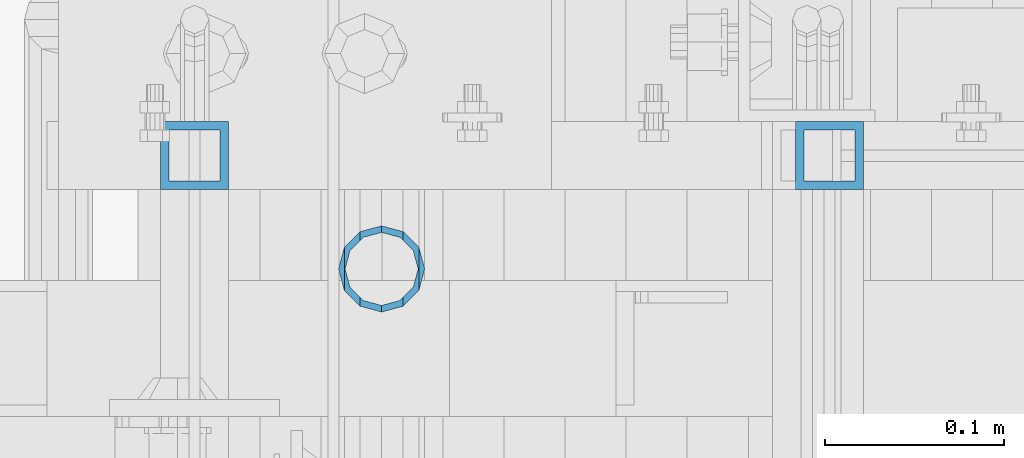
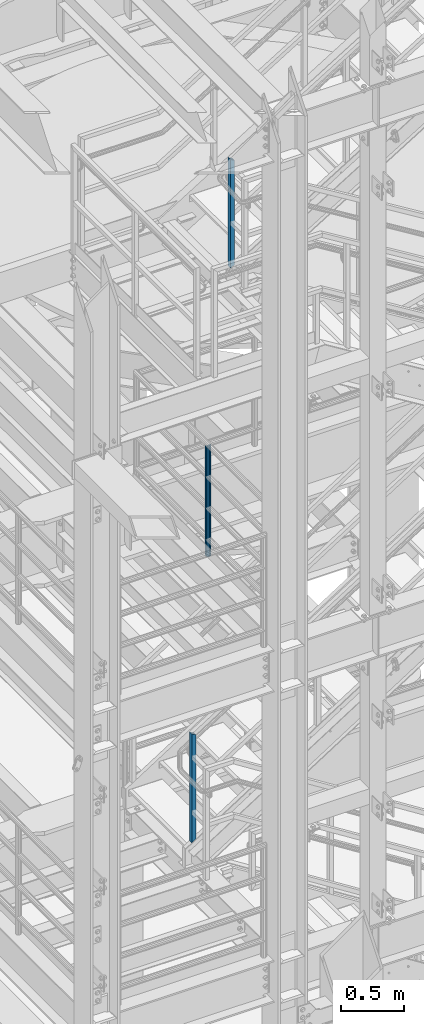
# One storey, part 602 of 1876: 3 columns, 3 elements without a shape of their own.
"""IFC2X3 building model written with IfcOpenShell, lengths in millimetres."""

from ifc_helpers import new_model, si_unit, frame, origin_with_axes, place, context, subcontext, project, spatial, faceted_brep, material, type_object, element, aggregate, save


model = new_model("IFC2X3")

# Units and contexts
model_context = context("Model", 3, precision=1e-05, world=origin_with_axes())
body_context = subcontext(model_context, "Body", "Model", "MODEL_VIEW")
ifc_project = project(units=[si_unit("LENGTHUNIT", "METRE", prefix="MILLI"), si_unit("AREAUNIT", "SQUARE_METRE"), si_unit("VOLUMEUNIT", "CUBIC_METRE"), si_unit("MASSUNIT", "GRAM", prefix="KILO"), si_unit("TIMEUNIT", "SECOND"), si_unit("PLANEANGLEUNIT", "RADIAN"), si_unit("SOLIDANGLEUNIT", "STERADIAN"), si_unit("THERMODYNAMICTEMPERATUREUNIT", "DEGREE_CELSIUS"), si_unit("LUMINOUSINTENSITYUNIT", "LUMEN")], contexts=[model_context])

# Site, building, storey
site_placement = place(None, origin_with_axes())
site = spatial("IfcSite", under=ifc_project, at=site_placement, CompositionType="ELEMENT")
building_placement = place(site_placement, origin_with_axes())
building = spatial("IfcBuilding", under=site, at=building_placement, Name="Undefined", CompositionType="ELEMENT")
storey_placement = place(building_placement, origin_with_axes())
storey = spatial("IfcBuildingStorey", under=building, at=storey_placement, Name="Undefined", CompositionType="ELEMENT", Elevation=0.0)

# Assembly, column
assembly_1_placement = place(storey_placement, origin_with_axes())
assembly_1 = element("IfcElementAssembly", 1, at=assembly_1_placement, inside=storey, Name="RAIL", AssemblyPlace="NOTDEFINED", PredefinedType="RIGID_FRAME")
ifc_material_1 = material()
column_type_1 = type_object("IfcColumnType", Name="HSS1-1/2X1-1/2X3/16", PredefinedType="NOTDEFINED")
column_1_placement = place(assembly_1_placement, frame((1676.39999919088, -5734.05000114554, 5380.55913395095), z_axis=(-1.0, 0.0, 0.0), x_axis=(0.0, 0.0, 1.0)))
column_1 = element("IfcColumn", 2, at=column_1_placement, type_object=column_type_1, material=ifc_material_1, Name="POST", ObjectType="HSS1-1/2X1-1/2X3/16", context=body_context, shape_type="Brep", body=[
    faceted_brep([(9.09204508312268, 14.2874994260001, -14.2874994260001), (9.09204508312268, -14.2874994260001, -14.2874994260001), (1028.85007387741, -14.2874994260001, -14.2874994260001), (1028.85007387741, 14.2874994260001, -14.2874994260001), (-9.09204508310631, -14.2874994260001, 14.2874994260001), (1044.53620210125, -14.2874994260001, 14.2874994260001), (-9.09204508310631, 14.2874994260001, 14.2874994260001), (1044.53620210125, 14.2874994260001, 14.2874994260001), (12.1227267777067, 19.0499992349996, -19.0499992349996), (-12.1227267776903, 19.0499992349996, 19.0499992349996), (1047.15055680541, 19.0499992349996, 19.0499992350001), (1026.23571825648, 19.0499992349996, -19.0499992349996), (-12.1227267776903, -19.0499992349996, 19.0499992349996), (1047.15055680541, -19.0499992349996, 19.0499992350001), (12.1227267777067, -19.0499992349996, -19.0499992349996), (1026.23571825648, -19.0500000000002, -19.0499992349996)], [[[0, 1, 2, 3]], [[1, 4, 5, 2]], [[4, 6, 7, 5]], [[6, 0, 3, 7]], [[8, 9, 10, 11]], [[9, 12, 13, 10]], [[12, 14, 15, 13]], [[14, 8, 11, 15]], [[13, 15, 11, 10], [5, 7, 3, 2]], [[14, 12, 9, 8], [6, 4, 1, 0]]]),
])
aggregate(assembly_1, [column_1])

assembly_2_placement = place(storey_placement, origin_with_axes())
assembly_2 = element("IfcElementAssembly", 3, at=assembly_2_placement, inside=storey, Name="RAIL", AssemblyPlace="NOTDEFINED", PredefinedType="RIGID_FRAME")
column_2_placement = place(assembly_2_placement, frame((2032.00000034804, -5734.05000114554, 10848.9703063526), z_axis=(-1.0, 0.0, 0.0), x_axis=(0.0, 0.0, 1.0)))
column_2 = element("IfcColumn", 4, at=column_2_placement, type_object=column_type_1, material=ifc_material_1, Name="POST", ObjectType="HSS1-1/2X1-1/2X3/16", context=body_context, shape_type="Brep", body=[
    faceted_brep([(8.78902482575359, 14.2874994260001, -14.2874994260001), (8.78902482575359, -14.2874994260001, -14.2874994260001), (1028.99354243185, -14.2874994260001, -14.2874994260001), (1028.99354243185, 14.2874994260001, -14.2874994260001), (-8.78902482466219, -14.2874994260001, 14.2874994260001), (1044.96430667265, -14.2874994260001, 14.2874994260001), (-8.78902482466219, 14.2874994260001, 14.2874994260001), (1044.96430667265, 14.2874994260001, 14.2874994260001), (11.7186358969793, 19.0499992349996, -19.0499992349996), (-11.7186358969739, 19.0499992349996, 19.0499992349996), (1047.62609707731, 19.0499992349996, 19.0499992350001), (1026.33175871902, 19.0499992349996, -19.0499992350001), (-11.7186358969739, -19.0499992349996, 19.0499992349996), (1047.62609707731, -19.0499992349996, 19.0499992350001), (11.7186358969793, -19.0499992349996, -19.0499992349996), (1026.33175871902, -19.0500000000002, -19.0499992350001)], [[[0, 1, 2, 3]], [[1, 4, 5, 2]], [[4, 6, 7, 5]], [[6, 0, 3, 7]], [[8, 9, 10, 11]], [[9, 12, 13, 10]], [[12, 14, 15, 13]], [[14, 8, 11, 15]], [[13, 15, 11, 10], [5, 7, 3, 2]], [[14, 12, 9, 8], [6, 4, 1, 0]]]),
])
aggregate(assembly_2, [column_2])

assembly_3_placement = place(storey_placement, origin_with_axes())
assembly_3 = element("IfcElementAssembly", 5, at=assembly_3_placement, inside=storey, Name="RAIL", AssemblyPlace="NOTDEFINED", PredefinedType="RIGID_FRAME")
ifc_material_2 = material()
column_type_2 = type_object("IfcColumnType", Name="PIPE1-1/2SCH40", PredefinedType="NOTDEFINED")
column_3_placement = place(assembly_3_placement, frame((1781.17499999997, -5797.55000057278, 8153.40000000001), z_axis=(0.0, 1.0, 0.0), x_axis=(0.0, 0.0, 1.0)))
column_3 = element("IfcColumn", 6, at=column_3_placement, type_object=column_type_2, material=ifc_material_2, Name="POST", ObjectType="PIPE1-1/2SCH40", context=body_context, shape_type="Brep", body=[
    faceted_brep([(1055.42780700668, -12.0650000000001, 20.8971929933186), (1055.42780700668, -12.0650000000001, 15.8661214311805), (1054.93437856882, -10.2235000000001, 17.7076214311801), (1052.195, 0.0, 20.4470000000001), (1052.195, 0.0, 24.1300000000001), (1054.93437856882, 10.2235000000001, 17.7076214311801), (1055.42780700668, 12.0650000000001, 15.8661214311805), (1055.42780700668, 12.0650000000001, 20.8971929933186), (1076.325, 24.1300000000001, 0.0), (1064.26, 20.8971929933184, 12.0649999999996), (1064.25999999999, 20.8971929933186, -12.0649999999996), (1061.07042843786, 17.7076214311803, 10.2235000000001), (1063.80980700668, 20.4469999999999, 0.0), (1061.07042843786, 17.7076214311803, -10.2235000000001), (1055.42780700668, 12.0650000000001, -15.8661214311805), (1055.42780700667, 12.0649999999996, -20.8971929933186), (1054.93437856882, 10.2235000000001, -17.7076214311801), (1052.195, 0.0, -20.4470000000001), (1052.19499999999, 0.0, -24.1300000000001), (1055.42780700668, -12.0650000000001, -15.8661214311805), (1055.42780700667, -12.0649999999996, -20.8971929933186), (1054.93437856882, -10.2235000000001, -17.7076214311801), (1076.325, -24.1300000000001, 0.0), (1064.25999999999, -20.8971929933186, -12.0649999999996), (1064.26, -20.8971929933184, 12.0649999999996), (1061.07042843786, -17.7076214311803, -10.2235000000001), (1063.80980700668, -20.4469999999999, 0.0), (1061.07042843786, -17.7076214311803, 10.2235000000001), (0.0, -20.8971929933184, -12.0649999999996), (0.0, -12.0650000000001, -20.8971929933186), (-1.45519152283669e-11, 0.0, -24.130000000001), (0.0, 12.0650000000001, -20.8971929933186), (0.0, 20.8971929933184, -12.0649999999996), (0.0, 24.1299999999992, 0.0), (0.0, 20.8971929933184, 12.0649999999996), (0.0, 12.0650000000001, 20.8971929933186), (-1.45519152283669e-11, 0.0, 24.130000000001), (0.0, -12.0650000000001, 20.8971929933186), (0.0, -20.8971929933184, 12.0649999999996), (0.0, -24.1299999999992, 0.0), (0.0, -17.7076214311803, -10.2235000000001), (0.0, -10.2235000000001, -17.7076214311801), (-1.45519152283669e-11, 0.0, -20.4470000000001), (0.0, 10.2235000000001, -17.7076214311801), (0.0, 17.7076214311803, -10.2235000000001), (0.0, 20.4469999999999, 0.0), (0.0, 17.7076214311803, 10.2235000000001), (0.0, 10.2235000000001, 17.7076214311801), (-1.45519152283669e-11, 0.0, 20.4470000000001), (0.0, -10.2235000000001, 17.7076214311801), (0.0, -17.7076214311803, 10.2235000000001), (0.0, -20.4469999999999, 0.0)], [[[0, 1, 2, 3, 4]], [[4, 3, 5, 6, 7]], [[8, 9, 10]], [[7, 6, 11, 12, 13, 14, 15, 10, 9]], [[16, 17, 18, 15, 14]], [[19, 20, 18, 17, 21]], [[22, 23, 24]], [[24, 23, 20, 19, 25, 26, 27, 1, 0]], [[28, 29, 20, 23]], [[29, 30, 18, 20]], [[30, 31, 15, 18]], [[31, 32, 10, 15]], [[32, 33, 8, 10]], [[33, 34, 9, 8]], [[34, 35, 7, 9]], [[35, 36, 4, 7]], [[36, 37, 0, 4]], [[37, 38, 24, 0]], [[38, 39, 22, 24]], [[39, 28, 23, 22]], [[38, 37, 36, 35, 34, 33, 32, 31, 30, 29, 28, 39], [40, 41, 42, 43, 44, 45, 46, 47, 48, 49, 50, 51]], [[40, 51, 26, 25]], [[21, 41, 40, 25, 19]], [[42, 41, 21, 17]], [[43, 42, 17, 16]], [[44, 43, 16, 14, 13]], [[45, 44, 13, 12]], [[46, 45, 12, 11]], [[5, 47, 46, 11, 6]], [[48, 47, 5, 3]], [[49, 48, 3, 2]], [[50, 49, 2, 1, 27]], [[51, 50, 27, 26]]]),
])
aggregate(assembly_3, [column_3])

save(model, "model.ifc")
